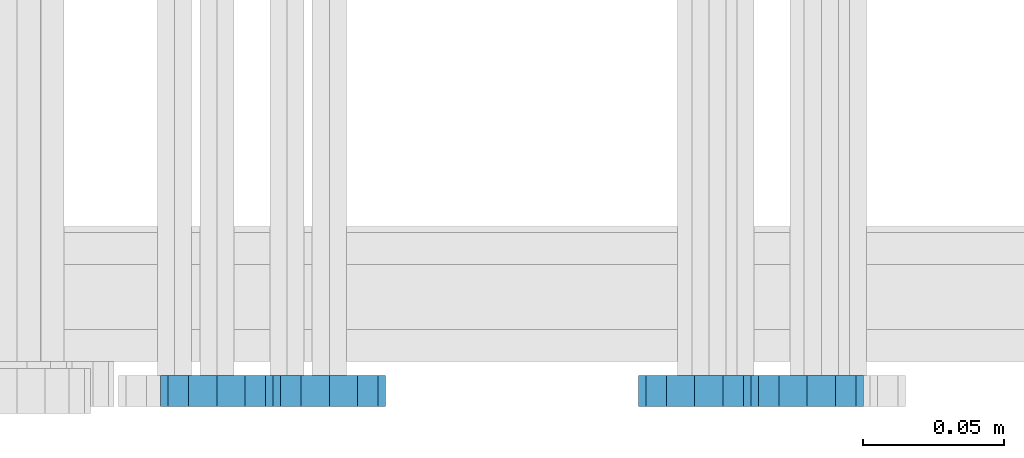
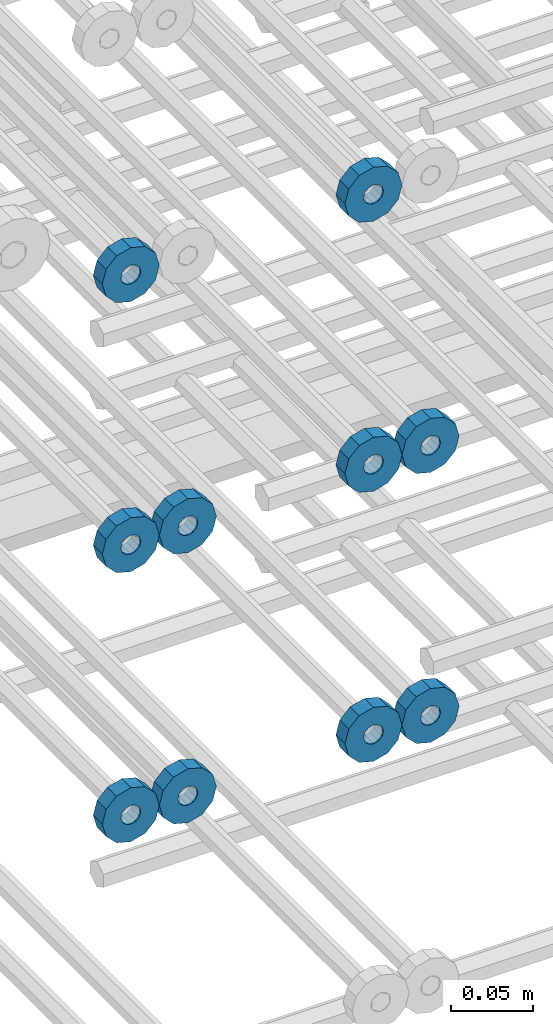
# One storey, part 160 of 177: 10 beams.
"""IFC2X3 building model written with IfcOpenShell, lengths in millimetres."""

import ifcopenshell
import ifcopenshell.guid

model = None  # the IFC model being written
_history = None  # IfcOwnerHistory: only IFC2X3 demands one
_inside = {}  # id of a spatial element -> (the spatial element, [elements in it])
_under = {}  # id of a project, library or spatial element -> (it, [spatial elements below it])
_declared = {}  # id of a project -> (the project, [libraries it declares])
_typed = {}  # id of a type object -> (the type object, [elements of that type])
_made_of = {}  # id of a material, layer set ... -> (it, [elements and type objects made of it])


def new_model(schema):
    """Start an empty IFC model of exactly this schema.

    Asked for "IFC4X3", IfcOpenShell would pick the latest addendum, in which some entities
    have other attributes; the version numbers below select the first issue.
    IFC2X3 requires an IfcOwnerHistory on every rooted entity: one is made here for all.
    """
    global model, _history
    if schema == "IFC4X3":
        model = ifcopenshell.file(schema_version=(4, 3, 0, 0))
    else:
        model = ifcopenshell.file(schema=schema)
    _inside.clear()
    _under.clear()
    _declared.clear()
    _typed.clear()
    _made_of.clear()
    _history = None
    if model.schema == "IFC2X3":
        org = make("IfcOrganization", Name="unknown")
        user = make(
            "IfcPersonAndOrganization",
            ThePerson=make("IfcPerson", FamilyName="unknown"),
            TheOrganization=org,
        )
        app = make(
            "IfcApplication",
            ApplicationDeveloper=org,
            Version="unknown",
            ApplicationFullName="unknown",
            ApplicationIdentifier="unknown",
        )
        _history = make(
            "IfcOwnerHistory",
            OwningUser=user,
            OwningApplication=app,
            ChangeAction="ADDED",
            CreationDate=0,
        )
    return model


def make(cls, **values):
    """One entity of the class cls with the attributes given. An attribute that is None is left unset."""
    return model.create_entity(
        cls, **{name: value for name, value in values.items() if value is not None}
    )


def rooted(cls, **values):
    """An entity with a GlobalId (a new one), such as an element, a storey or a relation."""
    return make(cls, GlobalId=ifcopenshell.guid.new(), OwnerHistory=_history, **values)


def si_unit(unit_type, name, prefix=None):
    """IfcSIUnit, for example si_unit("LENGTHUNIT", "METRE", prefix="MILLI")."""
    return make("IfcSIUnit", UnitType=unit_type, Prefix=prefix, Name=name)


def assignment(units):
    """IfcUnitAssignment: the units of a project."""
    return None if units is None else make("IfcUnitAssignment", Units=units)


def point(xyz):
    """IfcCartesianPoint."""
    return None if xyz is None else make("IfcCartesianPoint", Coordinates=xyz)


def direction(xyz):
    """IfcDirection."""
    return None if xyz is None else make("IfcDirection", DirectionRatios=xyz)


def frame(location, z_axis=None, x_axis=None):
    """IfcAxis2Placement3D, a coordinate frame: its origin and axes. An axis left out is left unset."""
    return make(
        "IfcAxis2Placement3D",
        Location=point(location),
        Axis=direction(z_axis),
        RefDirection=direction(x_axis),
    )


def origin_with_axes():
    """The frame at (0, 0, 0) with the z axis (0, 0, 1) and the x axis (1, 0, 0) written out."""
    return frame((0.0, 0.0, 0.0), z_axis=(0.0, 0.0, 1.0), x_axis=(1.0, 0.0, 0.0))


def place(relative_to, where):
    """IfcLocalPlacement: puts the frame where relative to a parent placement (None: the world)."""
    return make(
        "IfcLocalPlacement", PlacementRelTo=relative_to, RelativePlacement=where
    )


def context(
    kind, dimensions, precision=None, world=None, true_north=None, identifier=None
):
    """IfcGeometricRepresentationContext, for example the 3D "Model" context."""
    return make(
        "IfcGeometricRepresentationContext",
        ContextIdentifier=identifier,
        ContextType=kind,
        CoordinateSpaceDimension=dimensions,
        Precision=precision,
        WorldCoordinateSystem=world,
        TrueNorth=true_north,
    )


def subcontext(parent, identifier, kind, view, scale=None):
    """IfcGeometricRepresentationSubContext, for example "Body" below "Model"."""
    return make(
        "IfcGeometricRepresentationSubContext",
        ContextIdentifier=identifier,
        ContextType=kind,
        ParentContext=parent,
        TargetScale=scale,
        TargetView=view,
    )


def project(units=None, contexts=None):
    """IfcProject with its units and contexts."""
    return rooted(
        "IfcProject",
        Name="project",
        RepresentationContexts=contexts,
        UnitsInContext=assignment(units),
    )


def spatial(cls, under=None, at=None, **own):
    """A site, building, storey or space (cls), placed at a placement, below another one or the project."""
    s = rooted(cls, ObjectPlacement=at, **own)
    if under is not None:
        _under.setdefault(under.id(), (under, []))[1].append(s)
    return s


def faces_of(points, faces, orient=None, outer=None):
    """IfcFace entities. A face is a list of loops; a loop is a list of indices into points, from 0.

    orient and outer hold one flag for each loop. By default every Orientation is true, the
    first loop of a face is its IfcFaceOuterBound and the others are IfcFaceBound.
    """
    made = []
    for i, loops in enumerate(faces):
        bounds = []
        for j, loop in enumerate(loops):
            is_outer = j == 0 if outer is None else outer[i][j]
            bounds.append(
                make(
                    "IfcFaceOuterBound" if is_outer else "IfcFaceBound",
                    Bound=make("IfcPolyLoop", Polygon=[points[k] for k in loop]),
                    Orientation=True if orient is None else orient[i][j],
                )
            )
        made.append(make("IfcFace", Bounds=bounds))
    return made


def faceted_brep(points, faces, orient=None, outer=None, voids=None):
    """IfcFacetedBrep: a solid bounded by flat faces; with voids (closed shells), ...WithVoids."""
    shared = [point(p) for p in points]
    hull = make("IfcClosedShell", CfsFaces=faces_of(shared, faces, orient, outer))
    if voids is None:
        return make("IfcFacetedBrep", Outer=hull)
    return make(
        "IfcFacetedBrepWithVoids",
        Outer=hull,
        Voids=[
            make(cls, CfsFaces=faces_of(shared, fs, o, b)) for cls, fs, o, b in voids
        ],
    )


def shape(context_of_items, identifier, shape_type, items):
    """IfcShapeRepresentation: the items that make up one representation, for example the "Body"."""
    return make(
        "IfcShapeRepresentation",
        ContextOfItems=context_of_items,
        RepresentationIdentifier=identifier,
        RepresentationType=shape_type,
        Items=items,
    )


def material(Name=None, Category=None):
    """IfcMaterial."""
    return make("IfcMaterial", Name=Name, Category=Category)


def made_of(thing, what):
    """Note that an element or type object is made of a material, layer set ...; save() writes the relation."""
    if what is not None:
        _made_of.setdefault(what.id(), (what, []))[1].append(thing)
    return thing


def type_object(cls, material=None, **own):
    """A type object (cls), such as IfcWallType, which elements share."""
    return made_of(rooted(cls, **own), material)


def element(
    cls,
    number,
    at=None,
    inside=None,
    cuts=None,
    type_object=None,
    material=None,
    context=None,
    identifier="Body",
    shape_type=None,
    held_by="IfcProductDefinitionShape",
    body=None,
    shapes=None,
    **own,
):
    """One element of the class cls, such as IfcWall. Its Tag is "e" and its number.

    at: its placement. inside: the storey or other place that contains it. cuts: it is an
    opening in that element (IfcRelVoidsElement). A single representation is given by context,
    identifier, shape_type and body (its items); several are given by shapes. held_by: the class
    of the entity that holds the representations. save() writes the other relations.
    """
    e = rooted(cls, Tag="e%d" % number, ObjectPlacement=at, **own)
    if body is not None:
        shapes = [shape(context, identifier, shape_type, body)]
    if shapes is not None:
        e.Representation = make(held_by, Representations=shapes)
    if inside is not None:
        _inside.setdefault(inside.id(), (inside, []))[1].append(e)
    if cuts is not None:
        rooted(
            "IfcRelVoidsElement", RelatingBuildingElement=cuts, RelatedOpeningElement=e
        )
    if type_object is not None:
        _typed.setdefault(type_object.id(), (type_object, []))[1].append(e)
    return made_of(e, material)


def aggregate(whole, parts):
    """IfcRelAggregates: a whole, such as a stair, and the parts it consists of."""
    return rooted("IfcRelAggregates", RelatingObject=whole, RelatedObjects=parts)


def save(model, path):
    """Write the relations noted so far, then the file.

    IfcRelAggregates (storeys below a building ...), IfcRelContainedInSpatialStructure (elements
    in a storey), IfcRelDefinesByType, IfcRelAssociatesMaterial and IfcRelDeclares: one each for
    every whole, place, type object, material and project.
    """
    for whole, parts in _under.values():
        aggregate(whole, parts)
    for where, things in _inside.values():
        rooted(
            "IfcRelContainedInSpatialStructure",
            RelatedElements=things,
            RelatingStructure=where,
        )
    for kind, things in _typed.values():
        rooted("IfcRelDefinesByType", RelatedObjects=things, RelatingType=kind)
    for what, things in _made_of.values():
        rooted("IfcRelAssociatesMaterial", RelatedObjects=things, RelatingMaterial=what)
    for by, libraries in _declared.values():
        rooted("IfcRelDeclares", RelatingContext=by, RelatedDefinitions=libraries)
    model.write(path)


model = new_model("IFC2X3")

# Units and contexts
model_context_1 = context("Model", 3, precision=1e-05, world=origin_with_axes())
model_context_2 = context("Model", 3, precision=1e-05, world=origin_with_axes())
body_context = subcontext(model_context_2, "Body", "Model", "MODEL_VIEW")
ifc_project = project(units=[si_unit("LENGTHUNIT", "METRE", prefix="MILLI"), si_unit("AREAUNIT", "SQUARE_METRE"), si_unit("VOLUMEUNIT", "CUBIC_METRE"), si_unit("MASSUNIT", "GRAM", prefix="KILO"), si_unit("TIMEUNIT", "SECOND"), si_unit("PLANEANGLEUNIT", "RADIAN"), si_unit("SOLIDANGLEUNIT", "STERADIAN"), si_unit("THERMODYNAMICTEMPERATUREUNIT", "DEGREE_CELSIUS"), si_unit("LUMINOUSINTENSITYUNIT", "LUMEN")], contexts=[model_context_1])

# Site, building, storey
site_placement = place(None, origin_with_axes())
site = spatial("IfcSite", under=ifc_project, at=site_placement, CompositionType="ELEMENT")
building_placement = place(site_placement, origin_with_axes())
building = spatial("IfcBuilding", under=site, at=building_placement, Name="Undefined", CompositionType="ELEMENT")
storey_placement = place(building_placement, origin_with_axes())
storey = spatial("IfcBuildingStorey", under=building, at=storey_placement, Name="Undefined", CompositionType="ELEMENT", Elevation=0.0)

# Beams
ifc_material = material(Name="STEEL/Steel_Undefined")
beam_type = type_object("IfcBeamType", PredefinedType="NOTDEFINED")
beam_1_placement = place(storey_placement, frame((2035776.99847313, 6205070.98588033, 20824.9868114202), z_axis=(0.0, 0.0, -1.0), x_axis=(0.0, -1.0, 0.0)))
element("IfcBeam", 1, at=beam_1_placement, inside=storey, type_object=beam_type, material=ifc_material, context=body_context, shape_type="Brep", body=[
    faceted_brep([(-3.63797880709171e-12, -7.0, -2.3283064365387e-10), (-8.62348444298797e-13, -6.06217782649107, 3.5), (10.9999999999964, -6.06217782665044, 3.49999999976717), (10.9999999999964, -7.0, -2.3283064365387e-10), (-3.63797880709171e-12, -3.5, 6.06217782618478), (11.0, -3.5, 6.06217782618478), (-1.72469688859759e-12, 0.0, 7.0), (11.0, 0.0, 6.99999999976717), (-3.63797880709171e-12, 3.5, 6.06217782618478), (11.0, 3.5, 6.06217782618478), (-8.62348444298795e-13, 6.06217782649107, 3.5), (10.9999999999964, 6.06217782665044, 3.49999999976717), (-3.63797880709171e-12, 7.0, -2.3283064365387e-10), (10.9999999999964, 7.0, -2.3283064365387e-10), (8.62348444298797e-13, 6.06217782649107, -3.5), (10.9999999999964, 6.06217782665044, -3.50000000023283), (-3.63797880709171e-12, 3.5, -6.06217782665044), (10.9999999999964, 3.5, -6.06217782665044), (1.72469688859759e-12, -2.72004641033163e-15, -7.0), (10.9999999999964, 0.0, -7.00000000023283), (-3.63797880709171e-12, -3.5, -6.06217782665044), (10.9999999999964, -3.5, -6.06217782665044), (8.62348444298796e-13, -6.06217782649107, -3.5), (10.9999999999964, -6.06217782665044, -3.50000000023283), (0.0, -20.0000000009313, 0.0), (0.0, -17.320508075878, -10.0), (10.9999999999964, -17.320508075878, -10.0000000002328), (10.9999999999964, -20.0, -2.3283064365387e-10), (0.0, -10.0000000009313, -17.3205080756452), (11.0, -10.0, -17.320508075878), (0.0, -1.86264514923096e-09, -19.9999999998836), (10.9999999999964, 0.0, -20.0000000002328), (0.0, 9.99999999906868, -17.3205080755288), (11.0, 10.0, -17.320508075878), (0.0, 17.320508075878, -10.0), (10.9999999999964, 17.320508075878, -10.0000000002328), (0.0, 19.9999999990687, 0.0), (10.9999999999964, 20.0, -2.3283064365387e-10), (0.0, 17.3205080740154, 10.0), (11.0, 17.320508075878, 9.99999999976717), (0.0, 9.99999999906868, 17.3205080757616), (10.9999999999964, 10.0, 17.3205080754124), (0.0, 0.0, 20.0000000001164), (10.9999999999964, 0.0, 19.9999999997672), (0.0, -10.0000000009313, 17.3205080757616), (10.9999999999964, -10.0, 17.3205080754124), (0.0, -17.3205080777407, 10.0000000001164), (11.0, -17.320508075878, 9.99999999976717)], [[[0, 1, 2, 3]], [[1, 4, 5, 2]], [[4, 6, 7, 5]], [[6, 8, 9, 7]], [[8, 10, 11, 9]], [[10, 12, 13, 11]], [[12, 14, 15, 13]], [[14, 16, 17, 15]], [[16, 18, 19, 17]], [[18, 20, 21, 19]], [[20, 22, 23, 21]], [[22, 0, 3, 23]], [[24, 25, 26, 27]], [[25, 28, 29, 26]], [[28, 30, 31, 29]], [[30, 32, 33, 31]], [[32, 34, 35, 33]], [[34, 36, 37, 35]], [[36, 38, 39, 37]], [[38, 40, 41, 39]], [[40, 42, 43, 41]], [[42, 44, 45, 43]], [[44, 46, 47, 45]], [[46, 24, 27, 47]], [[29, 31, 33, 35, 37, 39, 41, 43, 45, 47, 27, 26], [5, 7, 9, 11, 13, 15, 17, 19, 21, 23, 3, 2]], [[46, 44, 42, 40, 38, 36, 34, 32, 30, 28, 25, 24], [22, 20, 18, 16, 14, 12, 10, 8, 6, 4, 1, 0]]]),
])
beam_2_placement = place(storey_placement, frame((2035606.99847313, 6205070.98588033, 20824.9868114254), z_axis=(0.0, 0.0, -1.0), x_axis=(0.0, -1.0, 0.0)))
element("IfcBeam", 2, at=beam_2_placement, inside=storey, type_object=beam_type, material=ifc_material, context=body_context, shape_type="Brep", body=[
    faceted_brep([(-3.63797880709171e-12, -7.0, -2.3283064365387e-10), (-8.62348444298797e-13, -6.06217782649107, 3.5), (10.9999999999964, -6.06217782665044, 3.49999999976717), (10.9999999999964, -7.0, -2.3283064365387e-10), (-3.63797880709171e-12, -3.5, 6.06217782618478), (11.0, -3.5, 6.06217782618478), (-1.72469688859759e-12, 0.0, 7.0), (11.0, 0.0, 6.99999999976717), (-3.63797880709171e-12, 3.5, 6.06217782618478), (11.0, 3.5, 6.06217782618478), (-8.62348444298795e-13, 6.06217782649107, 3.5), (10.9999999999964, 6.06217782665044, 3.49999999976717), (-3.63797880709171e-12, 7.0, -2.3283064365387e-10), (10.9999999999964, 7.0, -2.3283064365387e-10), (8.62348444298797e-13, 6.06217782649107, -3.5), (10.9999999999964, 6.06217782665044, -3.50000000023283), (-3.63797880709171e-12, 3.5, -6.06217782665044), (10.9999999999964, 3.5, -6.06217782665044), (1.72469688859759e-12, -2.72004641033163e-15, -7.0), (10.9999999999964, 0.0, -7.00000000023283), (-3.63797880709171e-12, -3.5, -6.06217782665044), (10.9999999999964, -3.5, -6.06217782665044), (8.62348444298796e-13, -6.06217782649107, -3.5), (10.9999999999964, -6.06217782665044, -3.50000000023283), (0.0, -20.0000000009313, 0.0), (0.0, -17.320508075878, -10.0), (10.9999999999964, -17.320508075878, -10.0000000002328), (10.9999999999964, -20.0, -2.3283064365387e-10), (0.0, -10.0000000009313, -17.3205080756452), (11.0, -10.0, -17.320508075878), (0.0, -1.86264514923096e-09, -19.9999999998836), (10.9999999999964, 0.0, -20.0000000002328), (0.0, 9.99999999906868, -17.3205080755288), (11.0, 10.0, -17.320508075878), (0.0, 17.320508075878, -10.0), (10.9999999999964, 17.320508075878, -10.0000000002328), (0.0, 19.9999999990687, 0.0), (10.9999999999964, 20.0, -2.3283064365387e-10), (0.0, 17.3205080740154, 10.0), (11.0, 17.320508075878, 9.99999999976717), (0.0, 9.99999999906868, 17.3205080757616), (10.9999999999964, 10.0, 17.3205080754124), (0.0, 0.0, 20.0000000001164), (10.9999999999964, 0.0, 19.9999999997672), (0.0, -10.0000000009313, 17.3205080757616), (10.9999999999964, -10.0, 17.3205080754124), (0.0, -17.3205080777407, 10.0000000001164), (11.0, -17.320508075878, 9.99999999976717)], [[[0, 1, 2, 3]], [[1, 4, 5, 2]], [[4, 6, 7, 5]], [[6, 8, 9, 7]], [[8, 10, 11, 9]], [[10, 12, 13, 11]], [[12, 14, 15, 13]], [[14, 16, 17, 15]], [[16, 18, 19, 17]], [[18, 20, 21, 19]], [[20, 22, 23, 21]], [[22, 0, 3, 23]], [[24, 25, 26, 27]], [[25, 28, 29, 26]], [[28, 30, 31, 29]], [[30, 32, 33, 31]], [[32, 34, 35, 33]], [[34, 36, 37, 35]], [[36, 38, 39, 37]], [[38, 40, 41, 39]], [[40, 42, 43, 41]], [[42, 44, 45, 43]], [[44, 46, 47, 45]], [[46, 24, 27, 47]], [[29, 31, 33, 35, 37, 39, 41, 43, 45, 47, 27, 26], [5, 7, 9, 11, 13, 15, 17, 19, 21, 23, 3, 2]], [[46, 44, 42, 40, 38, 36, 34, 32, 30, 28, 25, 24], [22, 20, 18, 16, 14, 12, 10, 8, 6, 4, 1, 0]]]),
])
beam_3_placement = place(storey_placement, frame((2035816.99847313, 6205070.98588034, 20624.9868114202), z_axis=(0.0, 0.0, -1.0), x_axis=(0.0, -1.0, 0.0)))
element("IfcBeam", 3, at=beam_3_placement, inside=storey, type_object=beam_type, material=ifc_material, context=body_context, shape_type="Brep", body=[
    faceted_brep([(-3.63797880709171e-12, -7.0, -2.3283064365387e-10), (-8.62348444298797e-13, -6.06217782649107, 3.5), (10.9999999999964, -6.06217782665044, 3.49999999976717), (10.9999999999964, -7.0, -2.3283064365387e-10), (-3.63797880709171e-12, -3.5, 6.06217782618478), (11.0, -3.5, 6.06217782618478), (-1.72469688859759e-12, 0.0, 7.0), (11.0, 0.0, 6.99999999976717), (-3.63797880709171e-12, 3.5, 6.06217782618478), (11.0, 3.5, 6.06217782618478), (-8.62348444298795e-13, 6.06217782649107, 3.5), (10.9999999999964, 6.06217782665044, 3.49999999976717), (-3.63797880709171e-12, 7.0, -2.3283064365387e-10), (10.9999999999964, 7.0, -2.3283064365387e-10), (8.62348444298797e-13, 6.06217782649107, -3.5), (10.9999999999964, 6.06217782665044, -3.50000000023283), (-3.63797880709171e-12, 3.5, -6.06217782665044), (10.9999999999964, 3.5, -6.06217782665044), (1.72469688859759e-12, -2.72004641033163e-15, -7.0), (10.9999999999964, 0.0, -7.00000000023283), (-3.63797880709171e-12, -3.5, -6.06217782665044), (10.9999999999964, -3.5, -6.06217782665044), (8.62348444298796e-13, -6.06217782649107, -3.5), (10.9999999999964, -6.06217782665044, -3.50000000023283), (0.0, -20.0000000009313, 0.0), (0.0, -17.320508075878, -10.0), (10.9999999999964, -17.320508075878, -10.0000000002328), (10.9999999999964, -20.0, -2.3283064365387e-10), (0.0, -10.0000000009313, -17.3205080756452), (11.0, -10.0, -17.320508075878), (0.0, -1.86264514923096e-09, -19.9999999998836), (10.9999999999964, 0.0, -20.0000000002328), (0.0, 9.99999999906868, -17.3205080755288), (11.0, 10.0, -17.320508075878), (0.0, 17.320508075878, -10.0), (10.9999999999964, 17.320508075878, -10.0000000002328), (0.0, 19.9999999990687, 0.0), (10.9999999999964, 20.0, -2.3283064365387e-10), (0.0, 17.3205080740154, 10.0), (11.0, 17.320508075878, 9.99999999976717), (0.0, 9.99999999906868, 17.3205080757616), (10.9999999999964, 10.0, 17.3205080754124), (0.0, 0.0, 20.0000000001164), (10.9999999999964, 0.0, 19.9999999997672), (0.0, -10.0000000009313, 17.3205080757616), (10.9999999999964, -10.0, 17.3205080754124), (0.0, -17.3205080777407, 10.0000000001164), (11.0, -17.320508075878, 9.99999999976717)], [[[0, 1, 2, 3]], [[1, 4, 5, 2]], [[4, 6, 7, 5]], [[6, 8, 9, 7]], [[8, 10, 11, 9]], [[10, 12, 13, 11]], [[12, 14, 15, 13]], [[14, 16, 17, 15]], [[16, 18, 19, 17]], [[18, 20, 21, 19]], [[20, 22, 23, 21]], [[22, 0, 3, 23]], [[24, 25, 26, 27]], [[25, 28, 29, 26]], [[28, 30, 31, 29]], [[30, 32, 33, 31]], [[32, 34, 35, 33]], [[34, 36, 37, 35]], [[36, 38, 39, 37]], [[38, 40, 41, 39]], [[40, 42, 43, 41]], [[42, 44, 45, 43]], [[44, 46, 47, 45]], [[46, 24, 27, 47]], [[29, 31, 33, 35, 37, 39, 41, 43, 45, 47, 27, 26], [5, 7, 9, 11, 13, 15, 17, 19, 21, 23, 3, 2]], [[46, 44, 42, 40, 38, 36, 34, 32, 30, 28, 25, 24], [22, 20, 18, 16, 14, 12, 10, 8, 6, 4, 1, 0]]]),
])
beam_4_placement = place(storey_placement, frame((2035646.99847313, 6205070.98588033, 20624.9868114254), z_axis=(0.0, 0.0, -1.0), x_axis=(0.0, -1.0, 0.0)))
element("IfcBeam", 4, at=beam_4_placement, inside=storey, type_object=beam_type, material=ifc_material, context=body_context, shape_type="Brep", body=[
    faceted_brep([(-3.63797880709171e-12, -7.0, -2.3283064365387e-10), (-8.62348444298797e-13, -6.06217782649107, 3.5), (10.9999999999964, -6.06217782665044, 3.49999999976717), (10.9999999999964, -7.0, -2.3283064365387e-10), (-3.63797880709171e-12, -3.5, 6.06217782618478), (11.0, -3.5, 6.06217782618478), (-1.72469688859759e-12, 0.0, 7.0), (11.0, 0.0, 6.99999999976717), (-3.63797880709171e-12, 3.5, 6.06217782618478), (11.0, 3.5, 6.06217782618478), (-8.62348444298795e-13, 6.06217782649107, 3.5), (10.9999999999964, 6.06217782665044, 3.49999999976717), (-3.63797880709171e-12, 7.0, -2.3283064365387e-10), (10.9999999999964, 7.0, -2.3283064365387e-10), (8.62348444298797e-13, 6.06217782649107, -3.5), (10.9999999999964, 6.06217782665044, -3.50000000023283), (-3.63797880709171e-12, 3.5, -6.06217782665044), (10.9999999999964, 3.5, -6.06217782665044), (1.72469688859759e-12, -2.72004641033163e-15, -7.0), (10.9999999999964, 0.0, -7.00000000023283), (-3.63797880709171e-12, -3.5, -6.06217782665044), (10.9999999999964, -3.5, -6.06217782665044), (8.62348444298796e-13, -6.06217782649107, -3.5), (10.9999999999964, -6.06217782665044, -3.50000000023283), (0.0, -20.0000000009313, 0.0), (0.0, -17.320508075878, -10.0), (10.9999999999964, -17.320508075878, -10.0000000002328), (10.9999999999964, -20.0, -2.3283064365387e-10), (0.0, -10.0000000009313, -17.3205080756452), (11.0, -10.0, -17.320508075878), (0.0, -1.86264514923096e-09, -19.9999999998836), (10.9999999999964, 0.0, -20.0000000002328), (0.0, 9.99999999906868, -17.3205080755288), (11.0, 10.0, -17.320508075878), (0.0, 17.320508075878, -10.0), (10.9999999999964, 17.320508075878, -10.0000000002328), (0.0, 19.9999999990687, 0.0), (10.9999999999964, 20.0, -2.3283064365387e-10), (0.0, 17.3205080740154, 10.0), (11.0, 17.320508075878, 9.99999999976717), (0.0, 9.99999999906868, 17.3205080757616), (10.9999999999964, 10.0, 17.3205080754124), (0.0, 0.0, 20.0000000001164), (10.9999999999964, 0.0, 19.9999999997672), (0.0, -10.0000000009313, 17.3205080757616), (10.9999999999964, -10.0, 17.3205080754124), (0.0, -17.3205080777407, 10.0000000001164), (11.0, -17.320508075878, 9.99999999976717)], [[[0, 1, 2, 3]], [[1, 4, 5, 2]], [[4, 6, 7, 5]], [[6, 8, 9, 7]], [[8, 10, 11, 9]], [[10, 12, 13, 11]], [[12, 14, 15, 13]], [[14, 16, 17, 15]], [[16, 18, 19, 17]], [[18, 20, 21, 19]], [[20, 22, 23, 21]], [[22, 0, 3, 23]], [[24, 25, 26, 27]], [[25, 28, 29, 26]], [[28, 30, 31, 29]], [[30, 32, 33, 31]], [[32, 34, 35, 33]], [[34, 36, 37, 35]], [[36, 38, 39, 37]], [[38, 40, 41, 39]], [[40, 42, 43, 41]], [[42, 44, 45, 43]], [[44, 46, 47, 45]], [[46, 24, 27, 47]], [[29, 31, 33, 35, 37, 39, 41, 43, 45, 47, 27, 26], [5, 7, 9, 11, 13, 15, 17, 19, 21, 23, 3, 2]], [[46, 44, 42, 40, 38, 36, 34, 32, 30, 28, 25, 24], [22, 20, 18, 16, 14, 12, 10, 8, 6, 4, 1, 0]]]),
])
beam_5_placement = place(storey_placement, frame((2035776.99847313, 6205070.98588034, 20624.9868114202), z_axis=(0.0, 0.0, -1.0), x_axis=(0.0, -1.0, 0.0)))
element("IfcBeam", 5, at=beam_5_placement, inside=storey, type_object=beam_type, material=ifc_material, context=body_context, shape_type="Brep", body=[
    faceted_brep([(-3.63797880709171e-12, -7.0, -2.3283064365387e-10), (-8.62348444298797e-13, -6.06217782649107, 3.5), (10.9999999999964, -6.06217782665044, 3.49999999976717), (10.9999999999964, -7.0, -2.3283064365387e-10), (-3.63797880709171e-12, -3.5, 6.06217782618478), (11.0, -3.5, 6.06217782618478), (-1.72469688859759e-12, 0.0, 7.0), (11.0, 0.0, 6.99999999976717), (-3.63797880709171e-12, 3.5, 6.06217782618478), (11.0, 3.5, 6.06217782618478), (-8.62348444298795e-13, 6.06217782649107, 3.5), (10.9999999999964, 6.06217782665044, 3.49999999976717), (-3.63797880709171e-12, 7.0, -2.3283064365387e-10), (10.9999999999964, 7.0, -2.3283064365387e-10), (8.62348444298797e-13, 6.06217782649107, -3.5), (10.9999999999964, 6.06217782665044, -3.50000000023283), (-3.63797880709171e-12, 3.5, -6.06217782665044), (10.9999999999964, 3.5, -6.06217782665044), (1.72469688859759e-12, -2.72004641033163e-15, -7.0), (10.9999999999964, 0.0, -7.00000000023283), (-3.63797880709171e-12, -3.5, -6.06217782665044), (10.9999999999964, -3.5, -6.06217782665044), (8.62348444298796e-13, -6.06217782649107, -3.5), (10.9999999999964, -6.06217782665044, -3.50000000023283), (0.0, -20.0000000009313, 0.0), (0.0, -17.320508075878, -10.0), (10.9999999999964, -17.320508075878, -10.0000000002328), (10.9999999999964, -20.0, -2.3283064365387e-10), (0.0, -10.0000000009313, -17.3205080756452), (11.0, -10.0, -17.320508075878), (0.0, -1.86264514923096e-09, -19.9999999998836), (10.9999999999964, 0.0, -20.0000000002328), (0.0, 9.99999999906868, -17.3205080755288), (11.0, 10.0, -17.320508075878), (0.0, 17.320508075878, -10.0), (10.9999999999964, 17.320508075878, -10.0000000002328), (0.0, 19.9999999990687, 0.0), (10.9999999999964, 20.0, -2.3283064365387e-10), (0.0, 17.3205080740154, 10.0), (11.0, 17.320508075878, 9.99999999976717), (0.0, 9.99999999906868, 17.3205080757616), (10.9999999999964, 10.0, 17.3205080754124), (0.0, 0.0, 20.0000000001164), (10.9999999999964, 0.0, 19.9999999997672), (0.0, -10.0000000009313, 17.3205080757616), (10.9999999999964, -10.0, 17.3205080754124), (0.0, -17.3205080777407, 10.0000000001164), (11.0, -17.320508075878, 9.99999999976717)], [[[0, 1, 2, 3]], [[1, 4, 5, 2]], [[4, 6, 7, 5]], [[6, 8, 9, 7]], [[8, 10, 11, 9]], [[10, 12, 13, 11]], [[12, 14, 15, 13]], [[14, 16, 17, 15]], [[16, 18, 19, 17]], [[18, 20, 21, 19]], [[20, 22, 23, 21]], [[22, 0, 3, 23]], [[24, 25, 26, 27]], [[25, 28, 29, 26]], [[28, 30, 31, 29]], [[30, 32, 33, 31]], [[32, 34, 35, 33]], [[34, 36, 37, 35]], [[36, 38, 39, 37]], [[38, 40, 41, 39]], [[40, 42, 43, 41]], [[42, 44, 45, 43]], [[44, 46, 47, 45]], [[46, 24, 27, 47]], [[29, 31, 33, 35, 37, 39, 41, 43, 45, 47, 27, 26], [5, 7, 9, 11, 13, 15, 17, 19, 21, 23, 3, 2]], [[46, 44, 42, 40, 38, 36, 34, 32, 30, 28, 25, 24], [22, 20, 18, 16, 14, 12, 10, 8, 6, 4, 1, 0]]]),
])
beam_6_placement = place(storey_placement, frame((2035606.99847313, 6205070.98588033, 20624.9868114254), z_axis=(0.0, 0.0, -1.0), x_axis=(0.0, -1.0, 0.0)))
element("IfcBeam", 6, at=beam_6_placement, inside=storey, type_object=beam_type, material=ifc_material, context=body_context, shape_type="Brep", body=[
    faceted_brep([(-3.63797880709171e-12, -7.0, -2.3283064365387e-10), (-8.62348444298797e-13, -6.06217782649107, 3.5), (10.9999999999964, -6.06217782665044, 3.49999999976717), (10.9999999999964, -7.0, -2.3283064365387e-10), (-3.63797880709171e-12, -3.5, 6.06217782618478), (11.0, -3.5, 6.06217782618478), (-1.72469688859759e-12, 0.0, 7.0), (11.0, 0.0, 6.99999999976717), (-3.63797880709171e-12, 3.5, 6.06217782618478), (11.0, 3.5, 6.06217782618478), (-8.62348444298795e-13, 6.06217782649107, 3.5), (10.9999999999964, 6.06217782665044, 3.49999999976717), (-3.63797880709171e-12, 7.0, -2.3283064365387e-10), (10.9999999999964, 7.0, -2.3283064365387e-10), (8.62348444298797e-13, 6.06217782649107, -3.5), (10.9999999999964, 6.06217782665044, -3.50000000023283), (-3.63797880709171e-12, 3.5, -6.06217782665044), (10.9999999999964, 3.5, -6.06217782665044), (1.72469688859759e-12, -2.72004641033163e-15, -7.0), (10.9999999999964, 0.0, -7.00000000023283), (-3.63797880709171e-12, -3.5, -6.06217782665044), (10.9999999999964, -3.5, -6.06217782665044), (8.62348444298796e-13, -6.06217782649107, -3.5), (10.9999999999964, -6.06217782665044, -3.50000000023283), (0.0, -20.0000000009313, 0.0), (0.0, -17.320508075878, -10.0), (10.9999999999964, -17.320508075878, -10.0000000002328), (10.9999999999964, -20.0, -2.3283064365387e-10), (0.0, -10.0000000009313, -17.3205080756452), (11.0, -10.0, -17.320508075878), (0.0, -1.86264514923096e-09, -19.9999999998836), (10.9999999999964, 0.0, -20.0000000002328), (0.0, 9.99999999906868, -17.3205080755288), (11.0, 10.0, -17.320508075878), (0.0, 17.320508075878, -10.0), (10.9999999999964, 17.320508075878, -10.0000000002328), (0.0, 19.9999999990687, 0.0), (10.9999999999964, 20.0, -2.3283064365387e-10), (0.0, 17.3205080740154, 10.0), (11.0, 17.320508075878, 9.99999999976717), (0.0, 9.99999999906868, 17.3205080757616), (10.9999999999964, 10.0, 17.3205080754124), (0.0, 0.0, 20.0000000001164), (10.9999999999964, 0.0, 19.9999999997672), (0.0, -10.0000000009313, 17.3205080757616), (10.9999999999964, -10.0, 17.3205080754124), (0.0, -17.3205080777407, 10.0000000001164), (11.0, -17.320508075878, 9.99999999976717)], [[[0, 1, 2, 3]], [[1, 4, 5, 2]], [[4, 6, 7, 5]], [[6, 8, 9, 7]], [[8, 10, 11, 9]], [[10, 12, 13, 11]], [[12, 14, 15, 13]], [[14, 16, 17, 15]], [[16, 18, 19, 17]], [[18, 20, 21, 19]], [[20, 22, 23, 21]], [[22, 0, 3, 23]], [[24, 25, 26, 27]], [[25, 28, 29, 26]], [[28, 30, 31, 29]], [[30, 32, 33, 31]], [[32, 34, 35, 33]], [[34, 36, 37, 35]], [[36, 38, 39, 37]], [[38, 40, 41, 39]], [[40, 42, 43, 41]], [[42, 44, 45, 43]], [[44, 46, 47, 45]], [[46, 24, 27, 47]], [[29, 31, 33, 35, 37, 39, 41, 43, 45, 47, 27, 26], [5, 7, 9, 11, 13, 15, 17, 19, 21, 23, 3, 2]], [[46, 44, 42, 40, 38, 36, 34, 32, 30, 28, 25, 24], [22, 20, 18, 16, 14, 12, 10, 8, 6, 4, 1, 0]]]),
])
beam_7_placement = place(storey_placement, frame((2035816.99847313, 6205070.98588034, 20424.9868114202), z_axis=(0.0, 0.0, -1.0), x_axis=(0.0, -1.0, 0.0)))
element("IfcBeam", 7, at=beam_7_placement, inside=storey, type_object=beam_type, material=ifc_material, context=body_context, shape_type="Brep", body=[
    faceted_brep([(-3.63797880709171e-12, -7.0, -2.3283064365387e-10), (-8.62348444298797e-13, -6.06217782649107, 3.5), (10.9999999999964, -6.06217782665044, 3.49999999976717), (10.9999999999964, -7.0, -2.3283064365387e-10), (-3.63797880709171e-12, -3.5, 6.06217782618478), (11.0, -3.5, 6.06217782618478), (-1.72469688859759e-12, 0.0, 7.0), (11.0, 0.0, 6.99999999976717), (-3.63797880709171e-12, 3.5, 6.06217782618478), (11.0, 3.5, 6.06217782618478), (-8.62348444298795e-13, 6.06217782649107, 3.5), (10.9999999999964, 6.06217782665044, 3.49999999976717), (-3.63797880709171e-12, 7.0, -2.3283064365387e-10), (10.9999999999964, 7.0, -2.3283064365387e-10), (8.62348444298797e-13, 6.06217782649107, -3.5), (10.9999999999964, 6.06217782665044, -3.50000000023283), (-3.63797880709171e-12, 3.5, -6.06217782665044), (10.9999999999964, 3.5, -6.06217782665044), (1.72469688859759e-12, -2.72004641033163e-15, -7.0), (10.9999999999964, 0.0, -7.00000000023283), (-3.63797880709171e-12, -3.5, -6.06217782665044), (10.9999999999964, -3.5, -6.06217782665044), (8.62348444298796e-13, -6.06217782649107, -3.5), (10.9999999999964, -6.06217782665044, -3.50000000023283), (0.0, -20.0000000009313, 0.0), (0.0, -17.320508075878, -10.0), (10.9999999999964, -17.320508075878, -10.0000000002328), (10.9999999999964, -20.0, -2.3283064365387e-10), (0.0, -10.0000000009313, -17.3205080756452), (11.0, -10.0, -17.320508075878), (0.0, -1.86264514923096e-09, -19.9999999998836), (10.9999999999964, 0.0, -20.0000000002328), (0.0, 9.99999999906868, -17.3205080755288), (11.0, 10.0, -17.320508075878), (0.0, 17.320508075878, -10.0), (10.9999999999964, 17.320508075878, -10.0000000002328), (0.0, 19.9999999990687, 0.0), (10.9999999999964, 20.0, -2.3283064365387e-10), (0.0, 17.3205080740154, 10.0), (11.0, 17.320508075878, 9.99999999976717), (0.0, 9.99999999906868, 17.3205080757616), (10.9999999999964, 10.0, 17.3205080754124), (0.0, 0.0, 20.0000000001164), (10.9999999999964, 0.0, 19.9999999997672), (0.0, -10.0000000009313, 17.3205080757616), (10.9999999999964, -10.0, 17.3205080754124), (0.0, -17.3205080777407, 10.0000000001164), (11.0, -17.320508075878, 9.99999999976717)], [[[0, 1, 2, 3]], [[1, 4, 5, 2]], [[4, 6, 7, 5]], [[6, 8, 9, 7]], [[8, 10, 11, 9]], [[10, 12, 13, 11]], [[12, 14, 15, 13]], [[14, 16, 17, 15]], [[16, 18, 19, 17]], [[18, 20, 21, 19]], [[20, 22, 23, 21]], [[22, 0, 3, 23]], [[24, 25, 26, 27]], [[25, 28, 29, 26]], [[28, 30, 31, 29]], [[30, 32, 33, 31]], [[32, 34, 35, 33]], [[34, 36, 37, 35]], [[36, 38, 39, 37]], [[38, 40, 41, 39]], [[40, 42, 43, 41]], [[42, 44, 45, 43]], [[44, 46, 47, 45]], [[46, 24, 27, 47]], [[29, 31, 33, 35, 37, 39, 41, 43, 45, 47, 27, 26], [5, 7, 9, 11, 13, 15, 17, 19, 21, 23, 3, 2]], [[46, 44, 42, 40, 38, 36, 34, 32, 30, 28, 25, 24], [22, 20, 18, 16, 14, 12, 10, 8, 6, 4, 1, 0]]]),
])
beam_8_placement = place(storey_placement, frame((2035646.99847313, 6205070.98588034, 20424.9868114254), z_axis=(0.0, 0.0, -1.0), x_axis=(0.0, -1.0, 0.0)))
element("IfcBeam", 8, at=beam_8_placement, inside=storey, type_object=beam_type, material=ifc_material, context=body_context, shape_type="Brep", body=[
    faceted_brep([(-3.63797880709171e-12, -7.0, -2.3283064365387e-10), (-8.62348444298797e-13, -6.06217782649107, 3.5), (10.9999999999964, -6.06217782665044, 3.49999999976717), (10.9999999999964, -7.0, -2.3283064365387e-10), (-3.63797880709171e-12, -3.5, 6.06217782618478), (11.0, -3.5, 6.06217782618478), (-1.72469688859759e-12, 0.0, 7.0), (11.0, 0.0, 6.99999999976717), (-3.63797880709171e-12, 3.5, 6.06217782618478), (11.0, 3.5, 6.06217782618478), (-8.62348444298795e-13, 6.06217782649107, 3.5), (10.9999999999964, 6.06217782665044, 3.49999999976717), (-3.63797880709171e-12, 7.0, -2.3283064365387e-10), (10.9999999999964, 7.0, -2.3283064365387e-10), (8.62348444298797e-13, 6.06217782649107, -3.5), (10.9999999999964, 6.06217782665044, -3.50000000023283), (-3.63797880709171e-12, 3.5, -6.06217782665044), (10.9999999999964, 3.5, -6.06217782665044), (1.72469688859759e-12, -2.72004641033163e-15, -7.0), (10.9999999999964, 0.0, -7.00000000023283), (-3.63797880709171e-12, -3.5, -6.06217782665044), (10.9999999999964, -3.5, -6.06217782665044), (8.62348444298796e-13, -6.06217782649107, -3.5), (10.9999999999964, -6.06217782665044, -3.50000000023283), (0.0, -20.0000000009313, 0.0), (0.0, -17.320508075878, -10.0), (10.9999999999964, -17.320508075878, -10.0000000002328), (10.9999999999964, -20.0, -2.3283064365387e-10), (0.0, -10.0000000009313, -17.3205080756452), (11.0, -10.0, -17.320508075878), (0.0, -1.86264514923096e-09, -19.9999999998836), (10.9999999999964, 0.0, -20.0000000002328), (0.0, 9.99999999906868, -17.3205080755288), (11.0, 10.0, -17.320508075878), (0.0, 17.320508075878, -10.0), (10.9999999999964, 17.320508075878, -10.0000000002328), (0.0, 19.9999999990687, 0.0), (10.9999999999964, 20.0, -2.3283064365387e-10), (0.0, 17.3205080740154, 10.0), (11.0, 17.320508075878, 9.99999999976717), (0.0, 9.99999999906868, 17.3205080757616), (10.9999999999964, 10.0, 17.3205080754124), (0.0, 0.0, 20.0000000001164), (10.9999999999964, 0.0, 19.9999999997672), (0.0, -10.0000000009313, 17.3205080757616), (10.9999999999964, -10.0, 17.3205080754124), (0.0, -17.3205080777407, 10.0000000001164), (11.0, -17.320508075878, 9.99999999976717)], [[[0, 1, 2, 3]], [[1, 4, 5, 2]], [[4, 6, 7, 5]], [[6, 8, 9, 7]], [[8, 10, 11, 9]], [[10, 12, 13, 11]], [[12, 14, 15, 13]], [[14, 16, 17, 15]], [[16, 18, 19, 17]], [[18, 20, 21, 19]], [[20, 22, 23, 21]], [[22, 0, 3, 23]], [[24, 25, 26, 27]], [[25, 28, 29, 26]], [[28, 30, 31, 29]], [[30, 32, 33, 31]], [[32, 34, 35, 33]], [[34, 36, 37, 35]], [[36, 38, 39, 37]], [[38, 40, 41, 39]], [[40, 42, 43, 41]], [[42, 44, 45, 43]], [[44, 46, 47, 45]], [[46, 24, 27, 47]], [[29, 31, 33, 35, 37, 39, 41, 43, 45, 47, 27, 26], [5, 7, 9, 11, 13, 15, 17, 19, 21, 23, 3, 2]], [[46, 44, 42, 40, 38, 36, 34, 32, 30, 28, 25, 24], [22, 20, 18, 16, 14, 12, 10, 8, 6, 4, 1, 0]]]),
])
beam_9_placement = place(storey_placement, frame((2035776.99847313, 6205070.98588034, 20424.9868114202), z_axis=(0.0, 0.0, -1.0), x_axis=(0.0, -1.0, 0.0)))
element("IfcBeam", 9, at=beam_9_placement, inside=storey, type_object=beam_type, material=ifc_material, context=body_context, shape_type="Brep", body=[
    faceted_brep([(-3.63797880709171e-12, -7.0, -2.3283064365387e-10), (-8.62348444298797e-13, -6.06217782649107, 3.5), (10.9999999999964, -6.06217782665044, 3.49999999976717), (10.9999999999964, -7.0, -2.3283064365387e-10), (-3.63797880709171e-12, -3.5, 6.06217782618478), (11.0, -3.5, 6.06217782618478), (-1.72469688859759e-12, 0.0, 7.0), (11.0, 0.0, 6.99999999976717), (-3.63797880709171e-12, 3.5, 6.06217782618478), (11.0, 3.5, 6.06217782618478), (-8.62348444298795e-13, 6.06217782649107, 3.5), (10.9999999999964, 6.06217782665044, 3.49999999976717), (-3.63797880709171e-12, 7.0, -2.3283064365387e-10), (10.9999999999964, 7.0, -2.3283064365387e-10), (8.62348444298797e-13, 6.06217782649107, -3.5), (10.9999999999964, 6.06217782665044, -3.50000000023283), (-3.63797880709171e-12, 3.5, -6.06217782665044), (10.9999999999964, 3.5, -6.06217782665044), (1.72469688859759e-12, -2.72004641033163e-15, -7.0), (10.9999999999964, 0.0, -7.00000000023283), (-3.63797880709171e-12, -3.5, -6.06217782665044), (10.9999999999964, -3.5, -6.06217782665044), (8.62348444298796e-13, -6.06217782649107, -3.5), (10.9999999999964, -6.06217782665044, -3.50000000023283), (0.0, -20.0000000009313, 0.0), (0.0, -17.320508075878, -10.0), (10.9999999999964, -17.320508075878, -10.0000000002328), (10.9999999999964, -20.0, -2.3283064365387e-10), (0.0, -10.0000000009313, -17.3205080756452), (11.0, -10.0, -17.320508075878), (0.0, -1.86264514923096e-09, -19.9999999998836), (10.9999999999964, 0.0, -20.0000000002328), (0.0, 9.99999999906868, -17.3205080755288), (11.0, 10.0, -17.320508075878), (0.0, 17.320508075878, -10.0), (10.9999999999964, 17.320508075878, -10.0000000002328), (0.0, 19.9999999990687, 0.0), (10.9999999999964, 20.0, -2.3283064365387e-10), (0.0, 17.3205080740154, 10.0), (11.0, 17.320508075878, 9.99999999976717), (0.0, 9.99999999906868, 17.3205080757616), (10.9999999999964, 10.0, 17.3205080754124), (0.0, 0.0, 20.0000000001164), (10.9999999999964, 0.0, 19.9999999997672), (0.0, -10.0000000009313, 17.3205080757616), (10.9999999999964, -10.0, 17.3205080754124), (0.0, -17.3205080777407, 10.0000000001164), (11.0, -17.320508075878, 9.99999999976717)], [[[0, 1, 2, 3]], [[1, 4, 5, 2]], [[4, 6, 7, 5]], [[6, 8, 9, 7]], [[8, 10, 11, 9]], [[10, 12, 13, 11]], [[12, 14, 15, 13]], [[14, 16, 17, 15]], [[16, 18, 19, 17]], [[18, 20, 21, 19]], [[20, 22, 23, 21]], [[22, 0, 3, 23]], [[24, 25, 26, 27]], [[25, 28, 29, 26]], [[28, 30, 31, 29]], [[30, 32, 33, 31]], [[32, 34, 35, 33]], [[34, 36, 37, 35]], [[36, 38, 39, 37]], [[38, 40, 41, 39]], [[40, 42, 43, 41]], [[42, 44, 45, 43]], [[44, 46, 47, 45]], [[46, 24, 27, 47]], [[29, 31, 33, 35, 37, 39, 41, 43, 45, 47, 27, 26], [5, 7, 9, 11, 13, 15, 17, 19, 21, 23, 3, 2]], [[46, 44, 42, 40, 38, 36, 34, 32, 30, 28, 25, 24], [22, 20, 18, 16, 14, 12, 10, 8, 6, 4, 1, 0]]]),
])
beam_10_placement = place(storey_placement, frame((2035606.99847313, 6205070.98588034, 20424.9868114254), z_axis=(0.0, 0.0, -1.0), x_axis=(0.0, -1.0, 0.0)))
element("IfcBeam", 10, at=beam_10_placement, inside=storey, type_object=beam_type, material=ifc_material, context=body_context, shape_type="Brep", body=[
    faceted_brep([(-3.63797880709171e-12, -7.0, -2.3283064365387e-10), (-8.62348444298797e-13, -6.06217782649107, 3.5), (10.9999999999964, -6.06217782665044, 3.49999999976717), (10.9999999999964, -7.0, -2.3283064365387e-10), (-3.63797880709171e-12, -3.5, 6.06217782618478), (11.0, -3.5, 6.06217782618478), (-1.72469688859759e-12, 0.0, 7.0), (11.0, 0.0, 6.99999999976717), (-3.63797880709171e-12, 3.5, 6.06217782618478), (11.0, 3.5, 6.06217782618478), (-8.62348444298795e-13, 6.06217782649107, 3.5), (10.9999999999964, 6.06217782665044, 3.49999999976717), (-3.63797880709171e-12, 7.0, -2.3283064365387e-10), (10.9999999999964, 7.0, -2.3283064365387e-10), (8.62348444298797e-13, 6.06217782649107, -3.5), (10.9999999999964, 6.06217782665044, -3.50000000023283), (-3.63797880709171e-12, 3.5, -6.06217782665044), (10.9999999999964, 3.5, -6.06217782665044), (1.72469688859759e-12, -2.72004641033163e-15, -7.0), (10.9999999999964, 0.0, -7.00000000023283), (-3.63797880709171e-12, -3.5, -6.06217782665044), (10.9999999999964, -3.5, -6.06217782665044), (8.62348444298796e-13, -6.06217782649107, -3.5), (10.9999999999964, -6.06217782665044, -3.50000000023283), (0.0, -20.0000000009313, 0.0), (0.0, -17.320508075878, -10.0), (10.9999999999964, -17.320508075878, -10.0000000002328), (10.9999999999964, -20.0, -2.3283064365387e-10), (0.0, -10.0000000009313, -17.3205080756452), (11.0, -10.0, -17.320508075878), (0.0, -1.86264514923096e-09, -19.9999999998836), (10.9999999999964, 0.0, -20.0000000002328), (0.0, 9.99999999906868, -17.3205080755288), (11.0, 10.0, -17.320508075878), (0.0, 17.320508075878, -10.0), (10.9999999999964, 17.320508075878, -10.0000000002328), (0.0, 19.9999999990687, 0.0), (10.9999999999964, 20.0, -2.3283064365387e-10), (0.0, 17.3205080740154, 10.0), (11.0, 17.320508075878, 9.99999999976717), (0.0, 9.99999999906868, 17.3205080757616), (10.9999999999964, 10.0, 17.3205080754124), (0.0, 0.0, 20.0000000001164), (10.9999999999964, 0.0, 19.9999999997672), (0.0, -10.0000000009313, 17.3205080757616), (10.9999999999964, -10.0, 17.3205080754124), (0.0, -17.3205080777407, 10.0000000001164), (11.0, -17.320508075878, 9.99999999976717)], [[[0, 1, 2, 3]], [[1, 4, 5, 2]], [[4, 6, 7, 5]], [[6, 8, 9, 7]], [[8, 10, 11, 9]], [[10, 12, 13, 11]], [[12, 14, 15, 13]], [[14, 16, 17, 15]], [[16, 18, 19, 17]], [[18, 20, 21, 19]], [[20, 22, 23, 21]], [[22, 0, 3, 23]], [[24, 25, 26, 27]], [[25, 28, 29, 26]], [[28, 30, 31, 29]], [[30, 32, 33, 31]], [[32, 34, 35, 33]], [[34, 36, 37, 35]], [[36, 38, 39, 37]], [[38, 40, 41, 39]], [[40, 42, 43, 41]], [[42, 44, 45, 43]], [[44, 46, 47, 45]], [[46, 24, 27, 47]], [[29, 31, 33, 35, 37, 39, 41, 43, 45, 47, 27, 26], [5, 7, 9, 11, 13, 15, 17, 19, 21, 23, 3, 2]], [[46, 44, 42, 40, 38, 36, 34, 32, 30, 28, 25, 24], [22, 20, 18, 16, 14, 12, 10, 8, 6, 4, 1, 0]]]),
])

save(model, "model.ifc")
